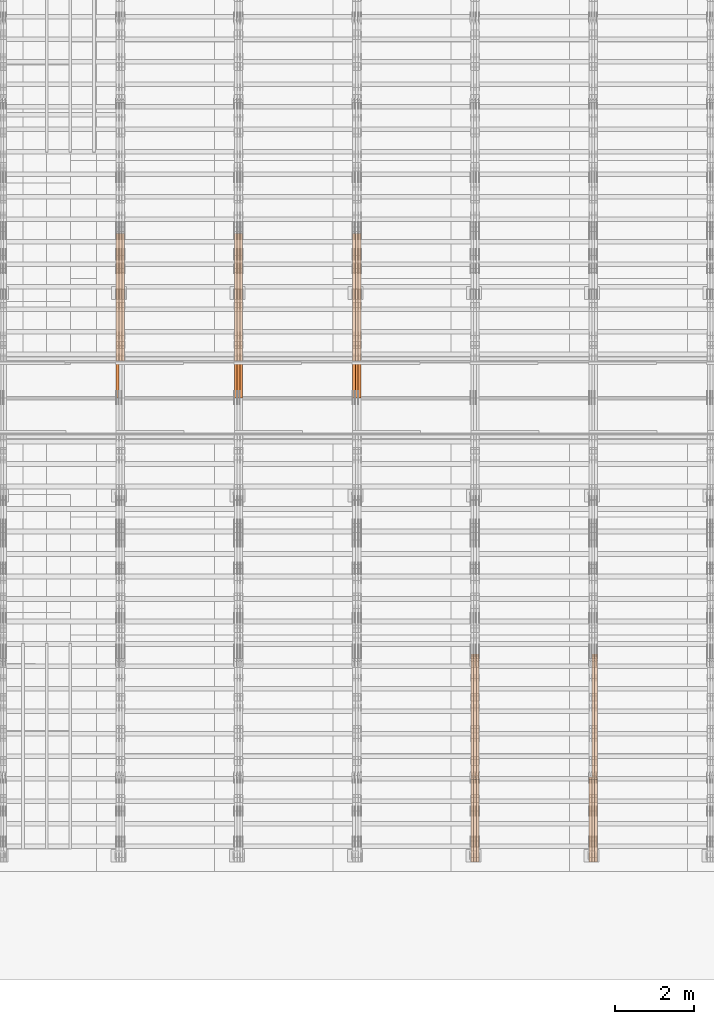
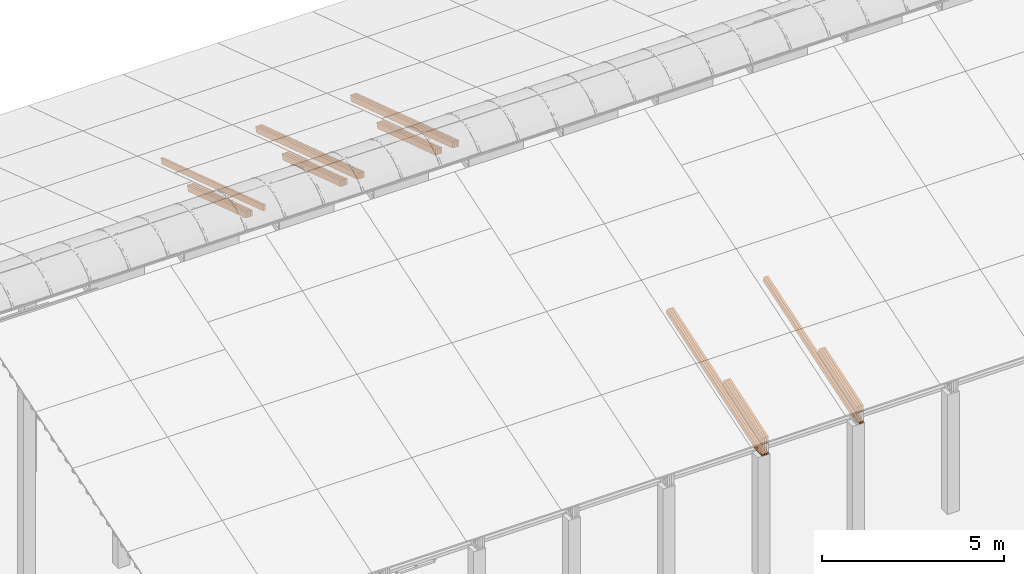
# One storey, part 15 of 385: 27 proxies.
"""IFC2X3 building model written with IfcOpenShell, lengths in millimetres."""

from ifc_helpers import new_model, entity, si_unit, converted_unit, derived_unit, direction, frame, origin, place, context, subcontext, project, spatial, polyline, outline, extrude, source, transform, mapped, material, type_object, type_shapes, element, save


model = new_model("IFC2X3")

# Units and contexts
model_context = context("Model", 3, precision=0.01, world=origin(), true_north=direction((6.12303176911189e-17, 1.0)))
body_context = subcontext(model_context, "Body", "Model", "MODEL_VIEW")
ifc_project = project(units=[si_unit("LENGTHUNIT", "METRE", prefix="MILLI"), si_unit("AREAUNIT", "SQUARE_METRE"), si_unit("VOLUMEUNIT", "CUBIC_METRE"), converted_unit("PLANEANGLEUNIT", "DEGREE", entity("IfcRatioMeasure", 0.0174532925199433), si_unit("PLANEANGLEUNIT", "RADIAN"), dimensions=[0, 0, 0, 0, 0, 0, 0]), si_unit("MASSUNIT", "GRAM", prefix="KILO"), derived_unit("MASSDENSITYUNIT", [(si_unit("MASSUNIT", "GRAM", prefix="KILO"), 1), (si_unit("LENGTHUNIT", "METRE"), -3)]), si_unit("TIMEUNIT", "SECOND"), si_unit("FREQUENCYUNIT", "HERTZ"), si_unit("THERMODYNAMICTEMPERATUREUNIT", "DEGREE_CELSIUS"), derived_unit("THERMALTRANSMITTANCEUNIT", [(si_unit("MASSUNIT", "GRAM", prefix="KILO"), 1), (si_unit("THERMODYNAMICTEMPERATUREUNIT", "KELVIN"), -1), (si_unit("TIMEUNIT", "SECOND"), -3)]), derived_unit("VOLUMETRICFLOWRATEUNIT", [(si_unit("LENGTHUNIT", "METRE"), 3), (si_unit("TIMEUNIT", "SECOND"), -1)]), si_unit("ELECTRICCURRENTUNIT", "AMPERE"), si_unit("ELECTRICVOLTAGEUNIT", "VOLT"), si_unit("POWERUNIT", "WATT"), si_unit("FORCEUNIT", "NEWTON", prefix="KILO"), si_unit("ILLUMINANCEUNIT", "LUX"), si_unit("LUMINOUSFLUXUNIT", "LUMEN"), si_unit("LUMINOUSINTENSITYUNIT", "CANDELA"), derived_unit("USERDEFINED", [(si_unit("MASSUNIT", "GRAM", prefix="KILO"), -1), (si_unit("LENGTHUNIT", "METRE"), -2), (si_unit("TIMEUNIT", "SECOND"), 3), (si_unit("LUMINOUSFLUXUNIT", "LUMEN"), 1)]), derived_unit("LINEARVELOCITYUNIT", [(si_unit("LENGTHUNIT", "METRE"), 1), (si_unit("TIMEUNIT", "SECOND"), -1)]), si_unit("PRESSUREUNIT", "PASCAL"), derived_unit("USERDEFINED", [(si_unit("LENGTHUNIT", "METRE"), -2), (si_unit("MASSUNIT", "GRAM", prefix="KILO"), 1), (si_unit("TIMEUNIT", "SECOND"), -2)])], contexts=[model_context])

# Site, building, storey
site_placement = place(None, origin())
site = spatial("IfcSite", under=ifc_project, at=site_placement, CompositionType="ELEMENT")
building_placement = place(site_placement, origin())
building = spatial("IfcBuilding", under=site, at=building_placement, CompositionType="ELEMENT")
storey_placement = place(building_placement, origin())
storey = spatial("IfcBuildingStorey", under=building, at=storey_placement, Name="Default", CompositionType="ELEMENT", Elevation=0.0)

# Proxies
ifc_material_1 = material(Name="IfcSurfaceStyle #248871")
building_element_proxy_type_1 = type_object("IfcBuildingElementProxyType", Name="T1-T3 248869", PredefinedType="NOTDEFINED", material=ifc_material_1)
shared_shape_1 = source(origin(), body_context, "Body", "SweptSolid", [
    extrude(outline(polyline([(-1085.54462735035, -97.5001496742589), (1117.22361141796, -97.5001496742589), (1117.22498157786, 97.5001496742589), (-1148.90396564547, 97.5001496742589), (-1085.54462735035, -97.5001496742589)])), frame((1117.22498157786, 97.5001496742589, 0.0), z_axis=(0.0, 0.0, 1.0), x_axis=(-1.0, 0.0, 0.0)), (0.0, 0.0, 1.0), 69.9999999999999),
])
type_shapes(building_element_proxy_type_1, [shared_shape_1])
proxy_1_placement = place(building_placement, frame((21385.0, 5095.216796875, 1095.23693847656), z_axis=(-1.0, 0.0, 0.0), x_axis=(0.0, -0.951056516295154, -0.309016994374948)))
element("IfcBuildingElementProxy", 1, at=proxy_1_placement, inside=storey, type_object=building_element_proxy_type_1, material=ifc_material_1, Name="T1-T3", context=body_context, shape_type="MappedRepresentation", body=[
    mapped(shared_shape_1, transform((0.0, 0.0, 0.0), scale=1.0)),
])
ifc_material_2 = material(Name="IfcSurfaceStyle #248814")
building_element_proxy_type_2 = type_object("IfcBuildingElementProxyType", Name="T1-T3 248812", PredefinedType="NOTDEFINED", material=ifc_material_2)
shared_shape_2 = source(origin(), body_context, "Body", "SweptSolid", [
    extrude(outline(polyline([(-1085.54462735035, -97.5001496742589), (1117.22361141796, -97.5001496742589), (1117.22498157786, 97.5001496742589), (-1148.90396564547, 97.5001496742589), (-1085.54462735035, -97.5001496742589)])), frame((1117.22498157786, 97.5001496742589, 0.0), z_axis=(0.0, 0.0, 1.0), x_axis=(-1.0, 0.0, 0.0)), (0.0, 0.0, 1.0), 69.9999999999999),
])
type_shapes(building_element_proxy_type_2, [shared_shape_2])
proxy_2_placement = place(building_placement, frame((21315.0, 5095.216796875, 1095.23693847656), z_axis=(-1.0, 0.0, 0.0), x_axis=(0.0, -0.951056516295154, -0.309016994374948)))
element("IfcBuildingElementProxy", 2, at=proxy_2_placement, inside=storey, type_object=building_element_proxy_type_2, material=ifc_material_2, Name="T1-T3", context=body_context, shape_type="MappedRepresentation", body=[
    mapped(shared_shape_2, transform((0.0, 0.0, 0.0), scale=1.0)),
])
ifc_material_3 = material(Name="IfcSurfaceStyle #248757")
building_element_proxy_type_3 = type_object("IfcBuildingElementProxyType", Name="T1-T3 248755", PredefinedType="NOTDEFINED", material=ifc_material_3)
shared_shape_3 = source(origin(), body_context, "Body", "SweptSolid", [
    extrude(outline(polyline([(-1085.54462735035, -97.5001496742589), (1117.22361141796, -97.5001496742589), (1117.22498157786, 97.5001496742589), (-1148.90396564547, 97.5001496742589), (-1085.54462735035, -97.5001496742589)])), frame((1117.22498157786, 97.5001496742589, 0.0), z_axis=(0.0, 0.0, 1.0), x_axis=(-1.0, 0.0, 0.0)), (0.0, 0.0, 1.0), 69.9999999999999),
])
type_shapes(building_element_proxy_type_3, [shared_shape_3])
proxy_3_placement = place(building_placement, frame((21245.0, 5095.216796875, 1095.23693847656), z_axis=(-1.0, 0.0, 0.0), x_axis=(0.0, -0.951056516295154, -0.309016994374948)))
element("IfcBuildingElementProxy", 3, at=proxy_3_placement, inside=storey, type_object=building_element_proxy_type_3, material=ifc_material_3, Name="T1-T3", context=body_context, shape_type="MappedRepresentation", body=[
    mapped(shared_shape_3, transform((0.0, 0.0, 0.0), scale=1.0)),
])
ifc_material_4 = material(Name="IfcSurfaceStyle #248187")
building_element_proxy_type_4 = type_object("IfcBuildingElementProxyType", Name="T1-B5 248185", PredefinedType="NOTDEFINED", material=ifc_material_4)
shared_shape_4 = source(origin(), body_context, "Body", "SweptSolid", [
    extrude(outline(polyline([(-3238.20553797979, -89.0131148793731), (1950.26357999126, -89.0131148793731), (2273.6227955316, 16.0525968934038), (2252.52438864378, 80.9868164326712), (-3238.20522618685, 80.9868164326712), (-3238.20553797979, -89.0131148793731)])), frame((2273.6227955316, 80.9869419088758, 0.0), z_axis=(0.0, 0.0, 1.0), x_axis=(-1.0, 0.0, 0.0)), (0.0, 0.0, 1.0), 69.9999999999997),
])
type_shapes(building_element_proxy_type_4, [shared_shape_4])
proxy_4_placement = place(building_placement, frame((21385.0, 2919.93418387161, 61.7562319586341), z_axis=(-1.0, 0.0, 0.0), x_axis=(0.0, 0.951056516295124, 0.309016994375039)))
element("IfcBuildingElementProxy", 4, at=proxy_4_placement, inside=storey, type_object=building_element_proxy_type_4, material=ifc_material_4, Name="T1-B5", context=body_context, shape_type="MappedRepresentation", body=[
    mapped(shared_shape_4, transform((0.0, 0.0, 0.0), scale=1.0)),
])
ifc_material_5 = material(Name="IfcSurfaceStyle #248121")
building_element_proxy_type_5 = type_object("IfcBuildingElementProxyType", Name="T1-B5 248119", PredefinedType="NOTDEFINED", material=ifc_material_5)
shared_shape_5 = source(origin(), body_context, "Body", "SweptSolid", [
    extrude(outline(polyline([(-3238.20553797979, -89.0131148793731), (1950.26357999126, -89.0131148793731), (2273.6227955316, 16.0525968934038), (2252.52438864378, 80.9868164326712), (-3238.20522618685, 80.9868164326712), (-3238.20553797979, -89.0131148793731)])), frame((2273.6227955316, 80.9869419088758, 0.0), z_axis=(0.0, 0.0, 1.0), x_axis=(-1.0, 0.0, 0.0)), (0.0, 0.0, 1.0), 69.9999999999997),
])
type_shapes(building_element_proxy_type_5, [shared_shape_5])
proxy_5_placement = place(building_placement, frame((21315.0, 2919.93418387161, 61.7562319586341), z_axis=(-1.0, 0.0, 0.0), x_axis=(0.0, 0.951056516295124, 0.309016994375039)))
element("IfcBuildingElementProxy", 5, at=proxy_5_placement, inside=storey, type_object=building_element_proxy_type_5, material=ifc_material_5, Name="T1-B5", context=body_context, shape_type="MappedRepresentation", body=[
    mapped(shared_shape_5, transform((0.0, 0.0, 0.0), scale=1.0)),
])
ifc_material_6 = material(Name="IfcSurfaceStyle #214439")
building_element_proxy_type_6 = type_object("IfcBuildingElementProxyType", Name="T1-T3 214437", PredefinedType="NOTDEFINED", material=ifc_material_6)
shared_shape_6 = source(origin(), body_context, "Body", "SweptSolid", [
    extrude(outline(polyline([(-1085.54462735035, -97.5001496742589), (1117.22361141796, -97.5001496742589), (1117.22498157786, 97.5001496742589), (-1148.90396564547, 97.5001496742589), (-1085.54462735035, -97.5001496742589)])), frame((1117.22498157786, 97.5001496742589, 0.0), z_axis=(0.0, 0.0, 1.0), x_axis=(-1.0, 0.0, 0.0)), (0.0, 0.0, 1.0), 69.9999999999999),
])
type_shapes(building_element_proxy_type_6, [shared_shape_6])
proxy_6_placement = place(building_placement, frame((18385.0, 5095.216796875, 1095.23693847656), z_axis=(-1.0, 0.0, 0.0), x_axis=(0.0, -0.951056516295154, -0.309016994374948)))
element("IfcBuildingElementProxy", 6, at=proxy_6_placement, inside=storey, type_object=building_element_proxy_type_6, material=ifc_material_6, Name="T1-T3", context=body_context, shape_type="MappedRepresentation", body=[
    mapped(shared_shape_6, transform((0.0, 0.0, 0.0), scale=1.0)),
])
ifc_material_7 = material(Name="IfcSurfaceStyle #214382")
building_element_proxy_type_7 = type_object("IfcBuildingElementProxyType", Name="T1-T3 214380", PredefinedType="NOTDEFINED", material=ifc_material_7)
shared_shape_7 = source(origin(), body_context, "Body", "SweptSolid", [
    extrude(outline(polyline([(-1085.54462735035, -97.5001496742589), (1117.22361141796, -97.5001496742589), (1117.22498157786, 97.5001496742589), (-1148.90396564547, 97.5001496742589), (-1085.54462735035, -97.5001496742589)])), frame((1117.22498157786, 97.5001496742589, 0.0), z_axis=(0.0, 0.0, 1.0), x_axis=(-1.0, 0.0, 0.0)), (0.0, 0.0, 1.0), 69.9999999999999),
])
type_shapes(building_element_proxy_type_7, [shared_shape_7])
proxy_7_placement = place(building_placement, frame((18315.0, 5095.216796875, 1095.23693847656), z_axis=(-1.0, 0.0, 0.0), x_axis=(0.0, -0.951056516295154, -0.309016994374948)))
element("IfcBuildingElementProxy", 7, at=proxy_7_placement, inside=storey, type_object=building_element_proxy_type_7, material=ifc_material_7, Name="T1-T3", context=body_context, shape_type="MappedRepresentation", body=[
    mapped(shared_shape_7, transform((0.0, 0.0, 0.0), scale=1.0)),
])
ifc_material_8 = material(Name="IfcSurfaceStyle #214325")
building_element_proxy_type_8 = type_object("IfcBuildingElementProxyType", Name="T1-T3 214323", PredefinedType="NOTDEFINED", material=ifc_material_8)
shared_shape_8 = source(origin(), body_context, "Body", "SweptSolid", [
    extrude(outline(polyline([(-1085.54462735035, -97.5001496742589), (1117.22361141796, -97.5001496742589), (1117.22498157786, 97.5001496742589), (-1148.90396564547, 97.5001496742589), (-1085.54462735035, -97.5001496742589)])), frame((1117.22498157786, 97.5001496742589, 0.0), z_axis=(0.0, 0.0, 1.0), x_axis=(-1.0, 0.0, 0.0)), (0.0, 0.0, 1.0), 69.9999999999999),
])
type_shapes(building_element_proxy_type_8, [shared_shape_8])
proxy_8_placement = place(building_placement, frame((18245.0, 5095.216796875, 1095.23693847656), z_axis=(-1.0, 0.0, 0.0), x_axis=(0.0, -0.951056516295154, -0.309016994374948)))
element("IfcBuildingElementProxy", 8, at=proxy_8_placement, inside=storey, type_object=building_element_proxy_type_8, material=ifc_material_8, Name="T1-T3", context=body_context, shape_type="MappedRepresentation", body=[
    mapped(shared_shape_8, transform((0.0, 0.0, 0.0), scale=1.0)),
])
ifc_material_9 = material(Name="IfcSurfaceStyle #213755")
building_element_proxy_type_9 = type_object("IfcBuildingElementProxyType", Name="T1-B5 213753", PredefinedType="NOTDEFINED", material=ifc_material_9)
shared_shape_9 = source(origin(), body_context, "Body", "SweptSolid", [
    extrude(outline(polyline([(-3238.20553797979, -89.0131148793731), (1950.26357999126, -89.0131148793731), (2273.6227955316, 16.0525968934038), (2252.52438864378, 80.9868164326712), (-3238.20522618685, 80.9868164326712), (-3238.20553797979, -89.0131148793731)])), frame((2273.6227955316, 80.9869419088758, 0.0), z_axis=(0.0, 0.0, 1.0), x_axis=(-1.0, 0.0, 0.0)), (0.0, 0.0, 1.0), 69.9999999999997),
])
type_shapes(building_element_proxy_type_9, [shared_shape_9])
proxy_9_placement = place(building_placement, frame((18385.0, 2919.93418387161, 61.7562319586341), z_axis=(-1.0, 0.0, 0.0), x_axis=(0.0, 0.951056516295124, 0.309016994375039)))
element("IfcBuildingElementProxy", 9, at=proxy_9_placement, inside=storey, type_object=building_element_proxy_type_9, material=ifc_material_9, Name="T1-B5", context=body_context, shape_type="MappedRepresentation", body=[
    mapped(shared_shape_9, transform((0.0, 0.0, 0.0), scale=1.0)),
])
ifc_material_10 = material(Name="IfcSurfaceStyle #213689")
building_element_proxy_type_10 = type_object("IfcBuildingElementProxyType", Name="T1-B5 213687", PredefinedType="NOTDEFINED", material=ifc_material_10)
shared_shape_10 = source(origin(), body_context, "Body", "SweptSolid", [
    extrude(outline(polyline([(-3238.20553797979, -89.0131148793731), (1950.26357999126, -89.0131148793731), (2273.6227955316, 16.0525968934038), (2252.52438864378, 80.9868164326712), (-3238.20522618685, 80.9868164326712), (-3238.20553797979, -89.0131148793731)])), frame((2273.6227955316, 80.9869419088758, 0.0), z_axis=(0.0, 0.0, 1.0), x_axis=(-1.0, 0.0, 0.0)), (0.0, 0.0, 1.0), 69.9999999999997),
])
type_shapes(building_element_proxy_type_10, [shared_shape_10])
proxy_10_placement = place(building_placement, frame((18315.0, 2919.93418387161, 61.7562319586341), z_axis=(-1.0, 0.0, 0.0), x_axis=(0.0, 0.951056516295124, 0.309016994375039)))
element("IfcBuildingElementProxy", 10, at=proxy_10_placement, inside=storey, type_object=building_element_proxy_type_10, material=ifc_material_10, Name="T1-B5", context=body_context, shape_type="MappedRepresentation", body=[
    mapped(shared_shape_10, transform((0.0, 0.0, 0.0), scale=1.0)),
])
ifc_material_11 = material(Name="IfcSurfaceStyle #213623")
building_element_proxy_type_11 = type_object("IfcBuildingElementProxyType", Name="T1-B5 213621", PredefinedType="NOTDEFINED", material=ifc_material_11)
shared_shape_11 = source(origin(), body_context, "Body", "SweptSolid", [
    extrude(outline(polyline([(-3238.20553797979, -89.0131148793731), (1950.26357999126, -89.0131148793731), (2273.6227955316, 16.0525968934038), (2252.52438864378, 80.9868164326712), (-3238.20522618685, 80.9868164326712), (-3238.20553797979, -89.0131148793731)])), frame((2273.6227955316, 80.9869419088758, 0.0), z_axis=(0.0, 0.0, 1.0), x_axis=(-1.0, 0.0, 0.0)), (0.0, 0.0, 1.0), 69.9999999999997),
])
type_shapes(building_element_proxy_type_11, [shared_shape_11])
proxy_11_placement = place(building_placement, frame((18245.0, 2919.93418387161, 61.7562319586341), z_axis=(-1.0, 0.0, 0.0), x_axis=(0.0, 0.951056516295124, 0.309016994375039)))
element("IfcBuildingElementProxy", 11, at=proxy_11_placement, inside=storey, type_object=building_element_proxy_type_11, material=ifc_material_11, Name="T1-B5", context=body_context, shape_type="MappedRepresentation", body=[
    mapped(shared_shape_11, transform((0.0, 0.0, 0.0), scale=1.0)),
])
ifc_material_12 = material(Name="IfcSurfaceStyle #180520")
building_element_proxy_type_12 = type_object("IfcBuildingElementProxyType", Name="T1-T1 180518", PredefinedType="NOTDEFINED", material=ifc_material_12)
shared_shape_12 = source(origin(), body_context, "Body", "SweptSolid", [
    extrude(outline(polyline([(-2970.52406677137, -97.5001477982598), (2938.84461360547, -97.5001477982598), (2938.8441722117, 97.5001477982599), (-2907.1647190458, 97.5001477982598), (-2970.52406677137, -97.5001477982598)])), frame((2938.84461360547, 97.5001477982598, 0.0), z_axis=(0.0, 0.0, 1.0), x_axis=(-1.0, 0.0, 0.0)), (0.0, 0.0, 1.0), 69.9999999999996),
])
type_shapes(building_element_proxy_type_12, [shared_shape_12])
proxy_12_placement = place(building_placement, frame((15385.0, 20279.8851854154, 2416.0025491487), z_axis=(-1.0, 0.0, 0.0), x_axis=(0.0, -0.951056516295154, 0.309016994374948)))
element("IfcBuildingElementProxy", 12, at=proxy_12_placement, inside=storey, type_object=building_element_proxy_type_12, material=ifc_material_12, Name="T1-T1", context=body_context, shape_type="MappedRepresentation", body=[
    mapped(shared_shape_12, transform((0.0, 0.0, 0.0), scale=1.0)),
])
ifc_material_13 = material(Name="IfcSurfaceStyle #180463")
building_element_proxy_type_13 = type_object("IfcBuildingElementProxyType", Name="T1-T1 180461", PredefinedType="NOTDEFINED", material=ifc_material_13)
shared_shape_13 = source(origin(), body_context, "Body", "SweptSolid", [
    extrude(outline(polyline([(-2970.52406677137, -97.5001477982598), (2938.84461360547, -97.5001477982598), (2938.8441722117, 97.5001477982599), (-2907.1647190458, 97.5001477982598), (-2970.52406677137, -97.5001477982598)])), frame((2938.84461360547, 97.5001477982598, 0.0), z_axis=(0.0, 0.0, 1.0), x_axis=(-1.0, 0.0, 0.0)), (0.0, 0.0, 1.0), 69.9999999999996),
])
type_shapes(building_element_proxy_type_13, [shared_shape_13])
proxy_13_placement = place(building_placement, frame((15315.0, 20279.8851854154, 2416.0025491487), z_axis=(-1.0, 0.0, 0.0), x_axis=(0.0, -0.951056516295154, 0.309016994374948)))
element("IfcBuildingElementProxy", 13, at=proxy_13_placement, inside=storey, type_object=building_element_proxy_type_13, material=ifc_material_13, Name="T1-T1", context=body_context, shape_type="MappedRepresentation", body=[
    mapped(shared_shape_13, transform((0.0, 0.0, 0.0), scale=1.0)),
])
ifc_material_14 = material(Name="IfcSurfaceStyle #180406")
building_element_proxy_type_14 = type_object("IfcBuildingElementProxyType", Name="T1-T1 180404", PredefinedType="NOTDEFINED", material=ifc_material_14)
shared_shape_14 = source(origin(), body_context, "Body", "SweptSolid", [
    extrude(outline(polyline([(-2970.52406677137, -97.5001477982598), (2938.84461360547, -97.5001477982598), (2938.8441722117, 97.5001477982599), (-2907.1647190458, 97.5001477982598), (-2970.52406677137, -97.5001477982598)])), frame((2938.84461360547, 97.5001477982598, 0.0), z_axis=(0.0, 0.0, 1.0), x_axis=(-1.0, 0.0, 0.0)), (0.0, 0.0, 1.0), 69.9999999999996),
])
type_shapes(building_element_proxy_type_14, [shared_shape_14])
proxy_14_placement = place(building_placement, frame((15245.0, 20279.8851854154, 2416.0025491487), z_axis=(-1.0, 0.0, 0.0), x_axis=(0.0, -0.951056516295154, 0.309016994374948)))
element("IfcBuildingElementProxy", 14, at=proxy_14_placement, inside=storey, type_object=building_element_proxy_type_14, material=ifc_material_14, Name="T1-T1", context=body_context, shape_type="MappedRepresentation", body=[
    mapped(shared_shape_14, transform((0.0, 0.0, 0.0), scale=1.0)),
])
ifc_material_15 = material(Name="IfcSurfaceStyle #179125")
building_element_proxy_type_15 = type_object("IfcBuildingElementProxyType", Name="T1-B3 179123", PredefinedType="NOTDEFINED", material=ifc_material_15)
shared_shape_15 = source(origin(), body_context, "Body", "SweptSolid", [
    extrude(outline(polyline([(-1715.8757175801, -97.4999653079672), (1684.19580003112, -97.4999653079672), (1684.19628740349, 97.4999653079672), (-1652.51636985451, 97.4999653079672), (-1715.8757175801, -97.4999653079672)])), frame((1684.19628740349, 97.5000561131842, 0.0), z_axis=(0.0, 0.0, 1.0), x_axis=(-1.0, 0.0, 0.0)), (0.0, 0.0, 1.0), 69.9999999999998),
])
type_shapes(building_element_proxy_type_15, [shared_shape_15])
proxy_15_placement = place(building_placement, frame((15385.0, 18833.4023156896, 2380.55582184223), z_axis=(-1.0, 0.0, 0.0), x_axis=(0.0, -0.951056516295124, 0.309016994375039)))
element("IfcBuildingElementProxy", 15, at=proxy_15_placement, inside=storey, type_object=building_element_proxy_type_15, material=ifc_material_15, Name="T1-B3", context=body_context, shape_type="MappedRepresentation", body=[
    mapped(shared_shape_15, transform((0.0, 0.0, 0.0), scale=1.0)),
])
ifc_material_16 = material(Name="IfcSurfaceStyle #179068")
building_element_proxy_type_16 = type_object("IfcBuildingElementProxyType", Name="T1-B3 179066", PredefinedType="NOTDEFINED", material=ifc_material_16)
shared_shape_16 = source(origin(), body_context, "Body", "SweptSolid", [
    extrude(outline(polyline([(-1715.8757175801, -97.4999653079672), (1684.19580003112, -97.4999653079672), (1684.19628740349, 97.4999653079672), (-1652.51636985451, 97.4999653079672), (-1715.8757175801, -97.4999653079672)])), frame((1684.19628740349, 97.5000561131842, 0.0), z_axis=(0.0, 0.0, 1.0), x_axis=(-1.0, 0.0, 0.0)), (0.0, 0.0, 1.0), 69.9999999999998),
])
type_shapes(building_element_proxy_type_16, [shared_shape_16])
proxy_16_placement = place(building_placement, frame((15315.0, 18833.4023156896, 2380.55582184223), z_axis=(-1.0, 0.0, 0.0), x_axis=(0.0, -0.951056516295124, 0.309016994375039)))
element("IfcBuildingElementProxy", 16, at=proxy_16_placement, inside=storey, type_object=building_element_proxy_type_16, material=ifc_material_16, Name="T1-B3", context=body_context, shape_type="MappedRepresentation", body=[
    mapped(shared_shape_16, transform((0.0, 0.0, 0.0), scale=1.0)),
])
ifc_material_17 = material(Name="IfcSurfaceStyle #179011")
building_element_proxy_type_17 = type_object("IfcBuildingElementProxyType", Name="T1-B3 179009", PredefinedType="NOTDEFINED", material=ifc_material_17)
shared_shape_17 = source(origin(), body_context, "Body", "SweptSolid", [
    extrude(outline(polyline([(-1715.8757175801, -97.4999653079672), (1684.19580003112, -97.4999653079672), (1684.19628740349, 97.4999653079672), (-1652.51636985451, 97.4999653079672), (-1715.8757175801, -97.4999653079672)])), frame((1684.19628740349, 97.5000561131842, 0.0), z_axis=(0.0, 0.0, 1.0), x_axis=(-1.0, 0.0, 0.0)), (0.0, 0.0, 1.0), 69.9999999999998),
])
type_shapes(building_element_proxy_type_17, [shared_shape_17])
proxy_17_placement = place(building_placement, frame((15245.0, 18833.4023156896, 2380.55582184223), z_axis=(-1.0, 0.0, 0.0), x_axis=(0.0, -0.951056516295124, 0.309016994375039)))
element("IfcBuildingElementProxy", 17, at=proxy_17_placement, inside=storey, type_object=building_element_proxy_type_17, material=ifc_material_17, Name="T1-B3", context=body_context, shape_type="MappedRepresentation", body=[
    mapped(shared_shape_17, transform((0.0, 0.0, 0.0), scale=1.0)),
])
ifc_material_18 = material(Name="IfcSurfaceStyle #146088")
building_element_proxy_type_18 = type_object("IfcBuildingElementProxyType", Name="T1-T1 146086", PredefinedType="NOTDEFINED", material=ifc_material_18)
shared_shape_18 = source(origin(), body_context, "Body", "SweptSolid", [
    extrude(outline(polyline([(-2970.52406677137, -97.5001477982598), (2938.84461360547, -97.5001477982598), (2938.8441722117, 97.5001477982599), (-2907.1647190458, 97.5001477982598), (-2970.52406677137, -97.5001477982598)])), frame((2938.84461360547, 97.5001477982598, 0.0), z_axis=(0.0, 0.0, 1.0), x_axis=(-1.0, 0.0, 0.0)), (0.0, 0.0, 1.0), 69.9999999999996),
])
type_shapes(building_element_proxy_type_18, [shared_shape_18])
proxy_18_placement = place(building_placement, frame((12385.0, 20279.8851854154, 2416.0025491487), z_axis=(-1.0, 0.0, 0.0), x_axis=(0.0, -0.951056516295154, 0.309016994374948)))
element("IfcBuildingElementProxy", 18, at=proxy_18_placement, inside=storey, type_object=building_element_proxy_type_18, material=ifc_material_18, Name="T1-T1", context=body_context, shape_type="MappedRepresentation", body=[
    mapped(shared_shape_18, transform((0.0, 0.0, 0.0), scale=1.0)),
])
ifc_material_19 = material(Name="IfcSurfaceStyle #146031")
building_element_proxy_type_19 = type_object("IfcBuildingElementProxyType", Name="T1-T1 146029", PredefinedType="NOTDEFINED", material=ifc_material_19)
shared_shape_19 = source(origin(), body_context, "Body", "SweptSolid", [
    extrude(outline(polyline([(-2970.52406677137, -97.5001477982598), (2938.84461360547, -97.5001477982598), (2938.8441722117, 97.5001477982599), (-2907.1647190458, 97.5001477982598), (-2970.52406677137, -97.5001477982598)])), frame((2938.84461360547, 97.5001477982598, 0.0), z_axis=(0.0, 0.0, 1.0), x_axis=(-1.0, 0.0, 0.0)), (0.0, 0.0, 1.0), 69.9999999999996),
])
type_shapes(building_element_proxy_type_19, [shared_shape_19])
proxy_19_placement = place(building_placement, frame((12315.0, 20279.8851854154, 2416.0025491487), z_axis=(-1.0, 0.0, 0.0), x_axis=(0.0, -0.951056516295154, 0.309016994374948)))
element("IfcBuildingElementProxy", 19, at=proxy_19_placement, inside=storey, type_object=building_element_proxy_type_19, material=ifc_material_19, Name="T1-T1", context=body_context, shape_type="MappedRepresentation", body=[
    mapped(shared_shape_19, transform((0.0, 0.0, 0.0), scale=1.0)),
])
ifc_material_20 = material(Name="IfcSurfaceStyle #145974")
building_element_proxy_type_20 = type_object("IfcBuildingElementProxyType", Name="T1-T1 145972", PredefinedType="NOTDEFINED", material=ifc_material_20)
shared_shape_20 = source(origin(), body_context, "Body", "SweptSolid", [
    extrude(outline(polyline([(-2970.52406677137, -97.5001477982598), (2938.84461360547, -97.5001477982598), (2938.8441722117, 97.5001477982599), (-2907.1647190458, 97.5001477982598), (-2970.52406677137, -97.5001477982598)])), frame((2938.84461360547, 97.5001477982598, 0.0), z_axis=(0.0, 0.0, 1.0), x_axis=(-1.0, 0.0, 0.0)), (0.0, 0.0, 1.0), 69.9999999999996),
])
type_shapes(building_element_proxy_type_20, [shared_shape_20])
proxy_20_placement = place(building_placement, frame((12245.0, 20279.8851854154, 2416.0025491487), z_axis=(-1.0, 0.0, 0.0), x_axis=(0.0, -0.951056516295154, 0.309016994374948)))
element("IfcBuildingElementProxy", 20, at=proxy_20_placement, inside=storey, type_object=building_element_proxy_type_20, material=ifc_material_20, Name="T1-T1", context=body_context, shape_type="MappedRepresentation", body=[
    mapped(shared_shape_20, transform((0.0, 0.0, 0.0), scale=1.0)),
])
ifc_material_21 = material(Name="IfcSurfaceStyle #144693")
building_element_proxy_type_21 = type_object("IfcBuildingElementProxyType", Name="T1-B3 144691", PredefinedType="NOTDEFINED", material=ifc_material_21)
shared_shape_21 = source(origin(), body_context, "Body", "SweptSolid", [
    extrude(outline(polyline([(-1715.8757175801, -97.4999653079672), (1684.19580003112, -97.4999653079672), (1684.19628740349, 97.4999653079672), (-1652.51636985451, 97.4999653079672), (-1715.8757175801, -97.4999653079672)])), frame((1684.19628740349, 97.5000561131842, 0.0), z_axis=(0.0, 0.0, 1.0), x_axis=(-1.0, 0.0, 0.0)), (0.0, 0.0, 1.0), 69.9999999999998),
])
type_shapes(building_element_proxy_type_21, [shared_shape_21])
proxy_21_placement = place(building_placement, frame((12385.0, 18833.4023156896, 2380.55582184223), z_axis=(-1.0, 0.0, 0.0), x_axis=(0.0, -0.951056516295124, 0.309016994375039)))
element("IfcBuildingElementProxy", 21, at=proxy_21_placement, inside=storey, type_object=building_element_proxy_type_21, material=ifc_material_21, Name="T1-B3", context=body_context, shape_type="MappedRepresentation", body=[
    mapped(shared_shape_21, transform((0.0, 0.0, 0.0), scale=1.0)),
])
ifc_material_22 = material(Name="IfcSurfaceStyle #144636")
building_element_proxy_type_22 = type_object("IfcBuildingElementProxyType", Name="T1-B3 144634", PredefinedType="NOTDEFINED", material=ifc_material_22)
shared_shape_22 = source(origin(), body_context, "Body", "SweptSolid", [
    extrude(outline(polyline([(-1715.8757175801, -97.4999653079672), (1684.19580003112, -97.4999653079672), (1684.19628740349, 97.4999653079672), (-1652.51636985451, 97.4999653079672), (-1715.8757175801, -97.4999653079672)])), frame((1684.19628740349, 97.5000561131842, 0.0), z_axis=(0.0, 0.0, 1.0), x_axis=(-1.0, 0.0, 0.0)), (0.0, 0.0, 1.0), 69.9999999999998),
])
type_shapes(building_element_proxy_type_22, [shared_shape_22])
proxy_22_placement = place(building_placement, frame((12315.0, 18833.4023156896, 2380.55582184223), z_axis=(-1.0, 0.0, 0.0), x_axis=(0.0, -0.951056516295124, 0.309016994375039)))
element("IfcBuildingElementProxy", 22, at=proxy_22_placement, inside=storey, type_object=building_element_proxy_type_22, material=ifc_material_22, Name="T1-B3", context=body_context, shape_type="MappedRepresentation", body=[
    mapped(shared_shape_22, transform((0.0, 0.0, 0.0), scale=1.0)),
])
ifc_material_23 = material(Name="IfcSurfaceStyle #144579")
building_element_proxy_type_23 = type_object("IfcBuildingElementProxyType", Name="T1-B3 144577", PredefinedType="NOTDEFINED", material=ifc_material_23)
shared_shape_23 = source(origin(), body_context, "Body", "SweptSolid", [
    extrude(outline(polyline([(-1715.8757175801, -97.4999653079672), (1684.19580003112, -97.4999653079672), (1684.19628740349, 97.4999653079672), (-1652.51636985451, 97.4999653079672), (-1715.8757175801, -97.4999653079672)])), frame((1684.19628740349, 97.5000561131842, 0.0), z_axis=(0.0, 0.0, 1.0), x_axis=(-1.0, 0.0, 0.0)), (0.0, 0.0, 1.0), 69.9999999999998),
])
type_shapes(building_element_proxy_type_23, [shared_shape_23])
proxy_23_placement = place(building_placement, frame((12245.0, 18833.4023156896, 2380.55582184223), z_axis=(-1.0, 0.0, 0.0), x_axis=(0.0, -0.951056516295124, 0.309016994375039)))
element("IfcBuildingElementProxy", 23, at=proxy_23_placement, inside=storey, type_object=building_element_proxy_type_23, material=ifc_material_23, Name="T1-B3", context=body_context, shape_type="MappedRepresentation", body=[
    mapped(shared_shape_23, transform((0.0, 0.0, 0.0), scale=1.0)),
])
ifc_material_24 = material(Name="IfcSurfaceStyle #111542")
building_element_proxy_type_24 = type_object("IfcBuildingElementProxyType", Name="T1-T1 111540", PredefinedType="NOTDEFINED", material=ifc_material_24)
shared_shape_24 = source(origin(), body_context, "Body", "SweptSolid", [
    extrude(outline(polyline([(-2970.52406677137, -97.5001477982598), (2938.84461360547, -97.5001477982598), (2938.8441722117, 97.5001477982599), (-2907.1647190458, 97.5001477982598), (-2970.52406677137, -97.5001477982598)])), frame((2938.84461360547, 97.5001477982598, 0.0), z_axis=(0.0, 0.0, 1.0), x_axis=(-1.0, 0.0, 0.0)), (0.0, 0.0, 1.0), 69.9999999999996),
])
type_shapes(building_element_proxy_type_24, [shared_shape_24])
proxy_24_placement = place(building_placement, frame((9245.0, 20279.8851854154, 2416.0025491487), z_axis=(-1.0, 0.0, 0.0), x_axis=(0.0, -0.951056516295154, 0.309016994374948)))
element("IfcBuildingElementProxy", 24, at=proxy_24_placement, inside=storey, type_object=building_element_proxy_type_24, material=ifc_material_24, Name="T1-T1", context=body_context, shape_type="MappedRepresentation", body=[
    mapped(shared_shape_24, transform((0.0, 0.0, 0.0), scale=1.0)),
])
ifc_material_25 = material(Name="IfcSurfaceStyle #110261")
building_element_proxy_type_25 = type_object("IfcBuildingElementProxyType", Name="T1-B3 110259", PredefinedType="NOTDEFINED", material=ifc_material_25)
shared_shape_25 = source(origin(), body_context, "Body", "SweptSolid", [
    extrude(outline(polyline([(-1715.8757175801, -97.4999653079672), (1684.19580003112, -97.4999653079672), (1684.19628740349, 97.4999653079672), (-1652.51636985451, 97.4999653079672), (-1715.8757175801, -97.4999653079672)])), frame((1684.19628740349, 97.5000561131842, 0.0), z_axis=(0.0, 0.0, 1.0), x_axis=(-1.0, 0.0, 0.0)), (0.0, 0.0, 1.0), 69.9999999999998),
])
type_shapes(building_element_proxy_type_25, [shared_shape_25])
proxy_25_placement = place(building_placement, frame((9385.0, 18833.4023156897, 2380.55582184223), z_axis=(-1.0, 0.0, 0.0), x_axis=(0.0, -0.951056516295124, 0.309016994375039)))
element("IfcBuildingElementProxy", 25, at=proxy_25_placement, inside=storey, type_object=building_element_proxy_type_25, material=ifc_material_25, Name="T1-B3", context=body_context, shape_type="MappedRepresentation", body=[
    mapped(shared_shape_25, transform((0.0, 0.0, 0.0), scale=1.0)),
])
ifc_material_26 = material(Name="IfcSurfaceStyle #110204")
building_element_proxy_type_26 = type_object("IfcBuildingElementProxyType", Name="T1-B3 110202", PredefinedType="NOTDEFINED", material=ifc_material_26)
shared_shape_26 = source(origin(), body_context, "Body", "SweptSolid", [
    extrude(outline(polyline([(-1715.8757175801, -97.4999653079672), (1684.19580003112, -97.4999653079672), (1684.19628740349, 97.4999653079672), (-1652.51636985451, 97.4999653079672), (-1715.8757175801, -97.4999653079672)])), frame((1684.19628740349, 97.5000561131842, 0.0), z_axis=(0.0, 0.0, 1.0), x_axis=(-1.0, 0.0, 0.0)), (0.0, 0.0, 1.0), 69.9999999999998),
])
type_shapes(building_element_proxy_type_26, [shared_shape_26])
proxy_26_placement = place(building_placement, frame((9315.0, 18833.4023156897, 2380.55582184223), z_axis=(-1.0, 0.0, 0.0), x_axis=(0.0, -0.951056516295124, 0.309016994375039)))
element("IfcBuildingElementProxy", 26, at=proxy_26_placement, inside=storey, type_object=building_element_proxy_type_26, material=ifc_material_26, Name="T1-B3", context=body_context, shape_type="MappedRepresentation", body=[
    mapped(shared_shape_26, transform((0.0, 0.0, 0.0), scale=1.0)),
])
ifc_material_27 = material(Name="IfcSurfaceStyle #110147")
building_element_proxy_type_27 = type_object("IfcBuildingElementProxyType", Name="T1-B3 110145", PredefinedType="NOTDEFINED", material=ifc_material_27)
shared_shape_27 = source(origin(), body_context, "Body", "SweptSolid", [
    extrude(outline(polyline([(-1715.8757175801, -97.4999653079672), (1684.19580003112, -97.4999653079672), (1684.19628740349, 97.4999653079672), (-1652.51636985451, 97.4999653079672), (-1715.8757175801, -97.4999653079672)])), frame((1684.19628740349, 97.5000561131842, 0.0), z_axis=(0.0, 0.0, 1.0), x_axis=(-1.0, 0.0, 0.0)), (0.0, 0.0, 1.0), 69.9999999999998),
])
type_shapes(building_element_proxy_type_27, [shared_shape_27])
proxy_27_placement = place(building_placement, frame((9245.0, 18833.4023156897, 2380.55582184223), z_axis=(-1.0, 0.0, 0.0), x_axis=(0.0, -0.951056516295124, 0.309016994375039)))
element("IfcBuildingElementProxy", 27, at=proxy_27_placement, inside=storey, type_object=building_element_proxy_type_27, material=ifc_material_27, Name="T1-B3", context=body_context, shape_type="MappedRepresentation", body=[
    mapped(shared_shape_27, transform((0.0, 0.0, 0.0), scale=1.0)),
])

save(model, "model.ifc")
